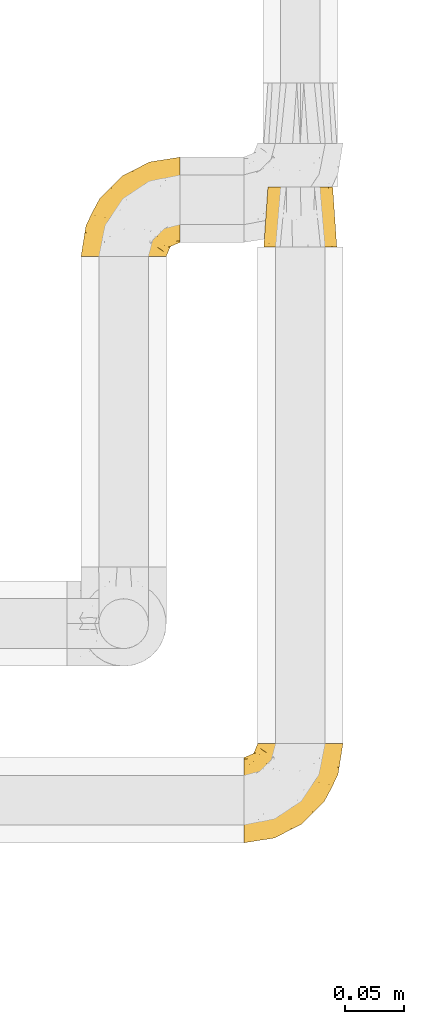
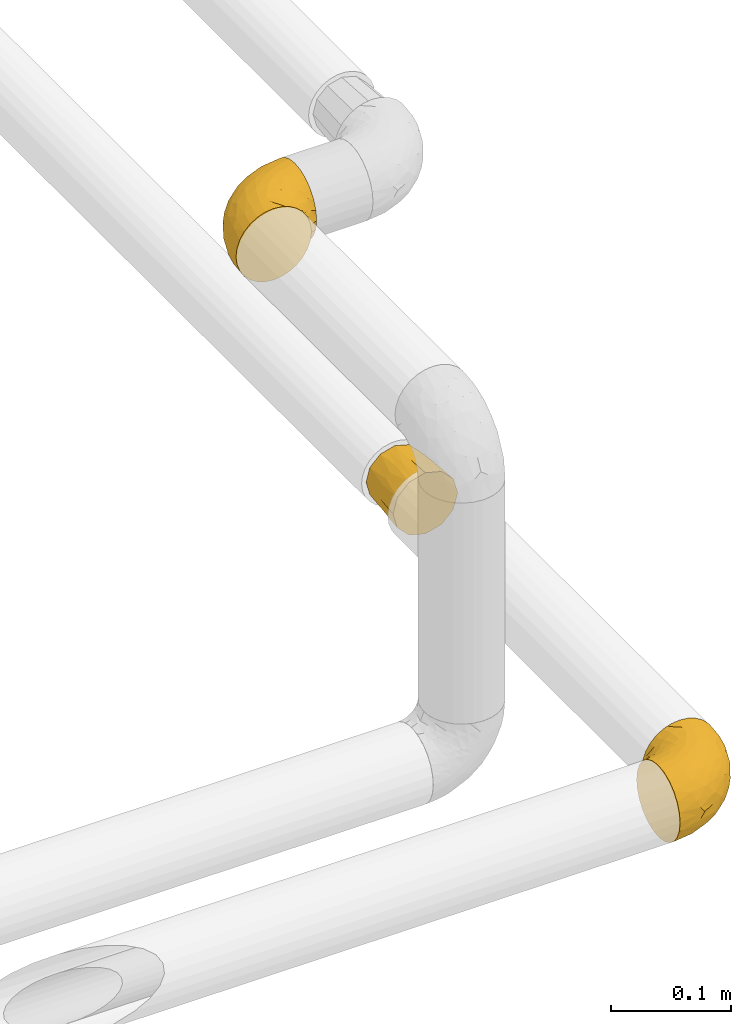
# One storey, part 24 of 39: 3 coverings.
"""IFC2X3 building model written with IfcOpenShell, lengths in millimetres."""

from ifc_helpers import new_model, entity, si_unit, converted_unit, derived_unit, direction, frame, origin, place, context, subcontext, project, spatial, faceted_brep, element, save


model = new_model("IFC2X3")

# Units and contexts
model_context = context("Model", 3, precision=0.01, world=origin(), true_north=direction((6.12303176911189e-17, 1.0)))
body_context = subcontext(model_context, "Body", "Model", "MODEL_VIEW")
ifc_project = project(units=[si_unit("LENGTHUNIT", "METRE", prefix="MILLI"), si_unit("AREAUNIT", "SQUARE_METRE"), si_unit("VOLUMEUNIT", "CUBIC_METRE"), converted_unit("PLANEANGLEUNIT", "DEGREE", entity("IfcRatioMeasure", 0.0174532925199433), si_unit("PLANEANGLEUNIT", "RADIAN"), dimensions=[0, 0, 0, 0, 0, 0, 0]), si_unit("MASSUNIT", "GRAM", prefix="KILO"), derived_unit("MASSDENSITYUNIT", [(si_unit("MASSUNIT", "GRAM", prefix="KILO"), 1), (si_unit("LENGTHUNIT", "METRE"), -3)]), derived_unit("MOMENTOFINERTIAUNIT", [(si_unit("LENGTHUNIT", "METRE"), 4)]), si_unit("TIMEUNIT", "SECOND"), si_unit("FREQUENCYUNIT", "HERTZ"), si_unit("THERMODYNAMICTEMPERATUREUNIT", "DEGREE_CELSIUS"), derived_unit("THERMALTRANSMITTANCEUNIT", [(si_unit("MASSUNIT", "GRAM", prefix="KILO"), 1), (si_unit("THERMODYNAMICTEMPERATUREUNIT", "KELVIN"), -1), (si_unit("TIMEUNIT", "SECOND"), -3)]), derived_unit("VOLUMETRICFLOWRATEUNIT", [(si_unit("LENGTHUNIT", "METRE"), 3), (si_unit("TIMEUNIT", "SECOND"), -1)]), derived_unit("MASSFLOWRATEUNIT", [(si_unit("MASSUNIT", "GRAM", prefix="KILO"), 1), (si_unit("TIMEUNIT", "SECOND"), -1)]), derived_unit("ROTATIONALFREQUENCYUNIT", [(si_unit("TIMEUNIT", "SECOND"), -1)]), si_unit("ELECTRICCURRENTUNIT", "AMPERE"), si_unit("ELECTRICVOLTAGEUNIT", "VOLT"), si_unit("POWERUNIT", "WATT"), si_unit("FORCEUNIT", "NEWTON", prefix="KILO"), si_unit("ILLUMINANCEUNIT", "LUX"), si_unit("LUMINOUSFLUXUNIT", "LUMEN"), si_unit("LUMINOUSINTENSITYUNIT", "CANDELA"), derived_unit("USERDEFINED", [(si_unit("MASSUNIT", "GRAM", prefix="KILO"), -1), (si_unit("LENGTHUNIT", "METRE"), -2), (si_unit("TIMEUNIT", "SECOND"), 3), (si_unit("LUMINOUSFLUXUNIT", "LUMEN"), 1)]), derived_unit("LINEARVELOCITYUNIT", [(si_unit("LENGTHUNIT", "METRE"), 1), (si_unit("TIMEUNIT", "SECOND"), -1)]), si_unit("PRESSUREUNIT", "PASCAL"), derived_unit("USERDEFINED", [(si_unit("LENGTHUNIT", "METRE"), -2), (si_unit("MASSUNIT", "GRAM", prefix="KILO"), 1), (si_unit("TIMEUNIT", "SECOND"), -2)]), derived_unit("LINEARFORCEUNIT", [(si_unit("MASSUNIT", "GRAM", prefix="KILO"), 1), (si_unit("LENGTHUNIT", "METRE"), 1), (si_unit("TIMEUNIT", "SECOND"), -2), (si_unit("LENGTHUNIT", "METRE"), -1)]), derived_unit("PLANARFORCEUNIT", [(si_unit("MASSUNIT", "GRAM", prefix="KILO"), 1), (si_unit("LENGTHUNIT", "METRE"), 1), (si_unit("TIMEUNIT", "SECOND"), -2), (si_unit("LENGTHUNIT", "METRE"), -2)])], contexts=[model_context])

# Site, building, storey
site_placement = place(None, origin())
site = spatial("IfcSite", under=ifc_project, at=site_placement, CompositionType="ELEMENT")
building_placement = place(site_placement, origin())
building = spatial("IfcBuilding", under=site, at=building_placement, CompositionType="ELEMENT")
storey_placement = place(building_placement, frame((0.0, 0.0, 24000.0)))
storey = spatial("IfcBuildingStorey", under=building, at=storey_placement, Name="07", CompositionType="ELEMENT", Elevation=24000.0)

# Coverings
covering_1_placement = place(storey_placement, frame((71732.42, 3195.35, 3047.4)))
element("IfcCovering", 1, at=covering_1_placement, inside=storey, Name=":ADSK_", ObjectType=":ADSK_", PredefinedType="INSULATION", context=body_context, shape_type="Brep", body=[
    faceted_brep([(59.44, 0.0, 17.1), (61.52, 0.0, 24.85), (63.6, 0.0, 32.6), (62.14, 0.0, 38.04), (60.68, 0.0, 43.48), (59.44, 0.0, 48.1), (53.77, 0.0, 53.77), (48.1, 0.0, 59.44), (40.35, 0.0, 61.52), (32.6, 0.0, 63.6), (27.15, 0.0, 62.14), (21.71, 0.0, 60.68), (17.1, 0.0, 59.44), (11.42, 0.0, 53.77), (5.75, 0.0, 48.1), (3.67, 0.0, 40.35), (1.6, 0.0, 32.6), (3.05, 0.0, 27.15), (4.51, 0.0, 21.71), (5.75, 0.0, 17.1), (11.42, 0.0, 11.42), (17.1, 0.0, 5.75), (24.85, 0.0, 3.67), (32.6, 0.0, 1.6), (38.04, 0.0, 3.05), (43.48, 0.0, 4.51), (48.1, 0.0, 5.75), (53.77, 0.0, 11.42), (46.35, 51.0, 56.41), (51.38, 51.0, 51.38), (56.41, 51.0, 46.35), (58.25, 51.0, 39.47), (60.1, 51.0, 32.6), (58.25, 51.0, 25.72), (56.41, 51.0, 18.85), (51.38, 51.0, 13.81), (46.35, 51.0, 8.78), (39.47, 51.0, 6.94), (32.6, 51.0, 5.1), (25.72, 51.0, 6.94), (18.85, 51.0, 8.78), (13.81, 51.0, 13.81), (8.78, 51.0, 18.85), (6.94, 51.0, 25.72), (5.1, 51.0, 32.6), (6.94, 51.0, 39.47), (8.78, 51.0, 46.35), (13.81, 51.0, 51.38), (18.85, 51.0, 56.41), (25.72, 51.0, 58.25), (32.6, 51.0, 60.1), (39.47, 51.0, 58.25), (6.2, 25.5, 19.99), (4.19, 24.88, 25.45), (10.36, 25.5, 13.59), (3.25, 24.18, 32.6), (19.99, 25.5, 6.2), (14.79, 25.5, 9.39), (32.6, 24.18, 3.25), (25.33, 25.5, 4.26), (45.2, 25.5, 6.2), (39.74, 24.88, 4.19), (51.6, 25.5, 10.36), (58.99, 25.5, 19.99), (55.8, 25.5, 14.79), (61.94, 24.18, 32.6), (60.93, 25.5, 25.33), (58.99, 25.5, 45.2), (61.0, 24.88, 39.74), (54.83, 25.5, 51.6), (45.2, 25.5, 58.99), (50.4, 25.5, 55.8), (32.6, 24.18, 61.94), (39.87, 25.5, 60.93), (19.99, 25.5, 58.99), (25.45, 24.88, 61.0), (13.59, 25.5, 54.83), (6.2, 25.5, 45.2), (9.39, 25.5, 50.4), (4.26, 25.5, 39.87)], [[[0, 1, 2, 3, 4, 5, 6, 7, 8, 9, 10, 11, 12, 13, 14, 15, 16, 17, 18, 19, 20, 21, 22, 23, 24, 25, 26, 27]], [[28, 29, 30, 31, 32, 33, 34, 35, 36, 37, 38, 39, 40, 41, 42, 43, 44, 45, 46, 47, 48, 49, 50, 51]], [[52, 43, 42]], [[52, 19, 18]], [[44, 43, 53]], [[17, 53, 18]], [[41, 54, 42]], [[17, 16, 55]], [[56, 21, 57]], [[41, 57, 54]], [[57, 41, 40]], [[58, 23, 59, 38]], [[57, 21, 20]], [[54, 19, 52]], [[53, 43, 52]], [[55, 44, 53]], [[57, 20, 54]], [[56, 57, 40]], [[19, 54, 20]], [[42, 54, 52]], [[18, 53, 52]], [[39, 59, 56]], [[56, 40, 39]], [[59, 22, 56]], [[22, 21, 56]], [[22, 59, 23]], [[55, 53, 17]], [[38, 59, 39]], [[60, 37, 36]], [[60, 26, 25]], [[38, 37, 61]], [[24, 61, 25]], [[35, 62, 36]], [[24, 23, 58]], [[63, 0, 64]], [[35, 64, 62]], [[64, 35, 34]], [[65, 2, 66, 32]], [[64, 0, 27]], [[62, 26, 60]], [[61, 37, 60]], [[58, 38, 61]], [[64, 27, 62]], [[63, 64, 34]], [[26, 62, 27]], [[36, 62, 60]], [[25, 61, 60]], [[33, 66, 63]], [[63, 34, 33]], [[66, 1, 63]], [[1, 0, 63]], [[1, 66, 2]], [[58, 61, 24]], [[32, 66, 33]], [[67, 31, 30]], [[67, 5, 4]], [[32, 31, 68]], [[3, 68, 4]], [[29, 69, 30]], [[3, 2, 65]], [[70, 7, 71]], [[29, 71, 69]], [[71, 29, 28]], [[72, 9, 73, 50]], [[71, 7, 6]], [[69, 5, 67]], [[68, 31, 67]], [[65, 32, 68]], [[71, 6, 69]], [[70, 71, 28]], [[5, 69, 6]], [[30, 69, 67]], [[4, 68, 67]], [[51, 73, 70]], [[70, 28, 51]], [[73, 8, 70]], [[8, 7, 70]], [[8, 73, 9]], [[65, 68, 3]], [[50, 73, 51]], [[74, 49, 48]], [[74, 12, 11]], [[50, 49, 75]], [[10, 75, 11]], [[47, 76, 48]], [[10, 9, 72]], [[77, 14, 78]], [[47, 78, 76]], [[78, 47, 46]], [[55, 16, 79, 44]], [[78, 14, 13]], [[76, 12, 74]], [[75, 49, 74]], [[72, 50, 75]], [[78, 13, 76]], [[77, 78, 46]], [[12, 76, 13]], [[48, 76, 74]], [[11, 75, 74]], [[45, 79, 77]], [[77, 46, 45]], [[79, 15, 77]], [[15, 14, 77]], [[15, 79, 16]], [[72, 75, 10]], [[44, 79, 45]]]),
])
covering_2_placement = place(storey_placement, frame((71715.42, 2687.56, 3042.2)))
element("IfcCovering", 2, at=covering_2_placement, inside=storey, Name=":ADSK_", ObjectType=":ADSK_", PredefinedType="INSULATION", context=body_context, shape_type="Brep", body=[
    faceted_brep([(57.65, 85.8, 73.09), (65.31, 85.8, 70.41), (72.17, 85.8, 66.09), (77.9, 85.8, 60.36), (82.21, 85.8, 53.5), (84.89, 85.8, 45.85), (85.8, 85.8, 37.8), (84.89, 85.8, 29.74), (82.21, 85.8, 22.08), (77.89, 85.8, 15.22), (72.16, 85.8, 9.49), (65.3, 85.8, 5.18), (57.65, 85.8, 2.5), (49.6, 85.8, 1.6), (44.33, 85.8, 2.19), (41.54, 85.8, 2.5), (37.71, 85.8, 3.84), (33.88, 85.8, 5.18), (27.02, 85.8, 9.5), (21.29, 85.8, 15.23), (16.98, 85.8, 22.09), (14.3, 85.8, 29.74), (13.4, 85.8, 37.8), (14.3, 85.8, 45.85), (16.98, 85.8, 53.51), (21.3, 85.8, 60.37), (27.03, 85.8, 66.1), (33.89, 85.8, 70.41), (37.72, 85.8, 71.75), (41.54, 85.8, 73.09), (44.33, 85.8, 73.4), (49.6, 85.8, 74.0), (1.6, 72.76, 28.43), (1.6, 69.15, 19.7), (1.6, 63.39, 12.2), (1.6, 59.64, 9.32), (1.6, 55.9, 6.45), (1.6, 51.53, 4.64), (1.6, 47.16, 2.83), (1.6, 43.08, 2.29), (1.6, 40.44, 1.94), (1.6, 37.8, 1.6), (1.6, 28.43, 2.83), (1.6, 19.7, 6.45), (1.6, 12.2, 12.2), (1.6, 6.45, 19.7), (1.6, 2.83, 28.43), (1.6, 1.6, 37.8), (1.6, 2.83, 47.16), (1.6, 6.45, 55.9), (1.6, 12.2, 63.39), (1.6, 19.7, 69.15), (1.6, 28.43, 72.76), (1.6, 37.8, 74.0), (1.6, 43.08, 73.3), (1.6, 47.16, 72.76), (1.6, 51.53, 70.95), (1.6, 55.9, 69.15), (1.6, 59.64, 66.27), (1.6, 63.39, 63.39), (1.6, 69.15, 55.9), (1.6, 72.76, 47.16), (1.6, 74.0, 37.8), (59.61, 27.78, 50.11), (60.4, 26.99, 37.8), (68.25, 36.07, 46.44), (27.62, 5.72, 37.8), (22.94, 4.9, 44.03), (19.4, 4.42, 37.8), (42.09, 13.52, 47.59), (33.53, 14.0, 57.17), (21.38, 6.28, 50.38), (16.47, 9.64, 58.65), (54.23, 70.93, 73.37), (38.23, 36.05, 71.27), (19.11, 24.02, 70.16), (36.76, 25.93, 66.97), (17.03, 32.56, 73.22), (19.96, 41.45, 74.0), (12.51, 39.97, 74.0), (9.78, 39.42, 74.0), (7.05, 38.88, 74.0), (21.71, 16.62, 64.86), (62.55, 71.64, 70.93), (75.89, 47.83, 45.2), (81.73, 65.91, 48.57), (74.04, 51.38, 54.32), (47.66, 52.81, 72.95), (45.94, 67.43, 74.0), (43.34, 63.53, 74.0), (40.74, 59.64, 74.0), (38.14, 55.75, 74.0), (35.54, 51.85, 74.0), (51.41, 41.26, 68.72), (30.21, 38.98, 73.34), (68.92, 70.65, 67.28), (74.03, 65.64, 61.7), (79.55, 71.08, 55.94), (82.98, 67.99, 37.8), (67.24, 38.62, 53.02), (55.48, 28.73, 57.31), (48.51, 80.34, 74.0), (47.42, 74.88, 74.0), (65.49, 52.52, 64.86), (64.99, 41.68, 59.15), (58.95, 56.44, 70.05), (45.7, 19.89, 55.98), (39.35, 11.7, 37.8), (53.72, 34.04, 63.54), (42.9, 22.66, 61.4), (81.67, 59.78, 37.8), (69.72, 36.3, 37.8), (75.69, 48.04, 37.8), (31.64, 49.25, 74.0), (27.75, 46.65, 74.0), (23.86, 44.05, 74.0), (51.09, 17.68, 37.8), (17.47, 56.47, 70.9), (18.36, 60.92, 69.2), (12.71, 63.29, 65.83), (7.84, 45.31, 73.31), (7.85, 59.83, 67.07), (6.14, 64.71, 62.53), (11.2, 74.49, 52.3), (14.99, 76.83, 54.94), (11.85, 78.01, 46.54), (23.69, 56.9, 72.08), (20.48, 50.18, 73.17), (14.49, 71.99, 59.32), (9.51, 70.83, 56.36), (6.6, 73.18, 48.99), (6.61, 68.29, 58.36), (26.46, 80.74, 66.05), (20.83, 78.17, 61.56), (28.69, 73.83, 68.98), (41.38, 76.97, 73.26), (7.16, 54.72, 70.05), (16.97, 47.37, 73.39), (12.64, 54.39, 70.87), (18.4, 74.3, 61.17), (35.97, 75.54, 71.9), (16.38, 66.46, 65.19), (11.31, 80.75, 37.8), (13.68, 81.71, 46.04), (15.78, 81.69, 52.15), (24.06, 72.63, 66.57), (9.94, 77.45, 37.8), (35.3, 62.19, 73.34), (36.41, 67.73, 72.91), (6.64, 76.08, 37.8), (10.52, 48.26, 72.75), (23.5, 62.83, 70.14), (29.62, 62.31, 72.14), (20.86, 68.86, 66.28), (29.66, 56.53, 73.22), (6.61, 68.29, 17.23), (6.59, 73.17, 26.6), (6.13, 64.71, 13.06), (48.51, 80.34, 1.6), (47.43, 74.88, 1.6), (13.67, 81.71, 29.56), (14.98, 76.83, 20.66), (15.78, 81.69, 23.45), (20.82, 78.17, 14.04), (4.33, 38.34, 1.6), (12.51, 39.97, 1.6), (7.05, 38.88, 1.6), (9.51, 70.83, 19.23), (11.19, 74.49, 23.3), (14.48, 72.0, 16.29), (10.19, 59.87, 8.09), (12.64, 54.39, 4.72), (7.16, 54.72, 5.54), (35.96, 75.53, 3.69), (10.52, 48.26, 2.84), (20.48, 50.18, 2.42), (17.47, 56.47, 4.69), (23.68, 56.9, 3.52), (16.97, 47.37, 2.21), (11.85, 78.01, 29.05), (7.85, 45.31, 2.29), (26.45, 80.74, 9.55), (18.4, 74.3, 14.43), (41.37, 76.96, 2.33), (20.85, 68.85, 9.32), (29.62, 62.32, 3.45), (23.5, 62.83, 5.45), (16.36, 66.46, 10.41), (35.87, 67.82, 2.81), (28.67, 73.83, 6.62), (45.94, 67.43, 1.6), (12.71, 63.29, 9.76), (24.04, 72.63, 9.03), (29.66, 56.54, 2.37), (30.95, 67.39, 4.15), (35.8, 62.12, 2.17), (43.34, 63.53, 1.6), (27.75, 46.65, 1.6), (31.64, 49.25, 1.6), (19.97, 41.45, 1.6), (23.86, 44.05, 1.6), (18.36, 60.93, 6.39), (40.74, 59.64, 1.6), (35.54, 51.85, 1.6), (38.14, 55.75, 1.6), (38.23, 36.06, 4.32), (17.03, 32.56, 2.37), (30.2, 38.98, 2.25), (64.98, 41.69, 16.43), (55.47, 28.72, 18.27), (53.71, 34.05, 12.04), (36.76, 25.93, 8.62), (51.4, 41.26, 6.87), (65.48, 52.53, 10.72), (47.66, 52.81, 2.65), (59.61, 27.78, 25.48), (45.7, 19.9, 19.59), (19.11, 24.02, 5.43), (22.94, 4.9, 31.57), (21.39, 6.28, 25.21), (58.94, 56.45, 5.53), (16.48, 9.64, 16.94), (21.71, 16.62, 10.73), (33.54, 14.0, 18.43), (74.04, 51.38, 21.26), (81.72, 65.91, 27.01), (75.89, 47.82, 30.39), (54.23, 70.94, 2.22), (74.02, 65.64, 13.88), (68.91, 70.65, 8.3), (42.09, 13.52, 28.0), (68.25, 36.08, 29.14), (67.24, 38.62, 22.56), (79.54, 71.07, 19.65), (42.91, 22.68, 14.18), (62.54, 71.64, 4.66)], [[[0, 1, 2, 3, 4, 5, 6, 7, 8, 9, 10, 11, 12, 13, 14, 15, 16, 17, 18, 19, 20, 21, 22, 23, 24, 25, 26, 27, 28, 29, 30, 31]], [[32, 33, 34, 35, 36, 37, 38, 39, 40, 41, 42, 43, 44, 45, 46, 47, 48, 49, 50, 51, 52, 53, 54, 55, 56, 57, 58, 59, 60, 61, 62]], [[63, 64, 65]], [[66, 67, 68]], [[69, 70, 71]], [[71, 70, 72]], [[73, 0, 31]], [[74, 75, 76]], [[49, 48, 71]], [[77, 78, 79, 80, 81, 53]], [[50, 82, 51]], [[72, 50, 49]], [[1, 0, 83]], [[84, 85, 86]], [[87, 88, 89, 90, 91, 92]], [[53, 52, 77]], [[93, 74, 76]], [[4, 85, 5]], [[94, 78, 77]], [[95, 2, 1]], [[95, 96, 2]], [[75, 51, 82]], [[85, 4, 97]], [[50, 72, 82]], [[97, 4, 3]], [[85, 98, 5]], [[94, 87, 92]], [[74, 77, 75]], [[99, 100, 63]], [[96, 3, 2]], [[73, 31, 101, 102, 88]], [[96, 103, 104]], [[48, 68, 67]], [[84, 99, 65]], [[105, 83, 73]], [[105, 95, 83]], [[100, 106, 63]], [[86, 96, 104]], [[97, 86, 85]], [[67, 107, 69]], [[100, 108, 109]], [[84, 110, 85]], [[93, 87, 74]], [[96, 95, 103]], [[69, 71, 67]], [[70, 69, 106]], [[3, 96, 97]], [[86, 97, 96]], [[83, 95, 1]], [[103, 95, 105]], [[93, 103, 105]], [[103, 108, 104]], [[75, 77, 52]], [[94, 77, 74]], [[51, 75, 52]], [[75, 82, 76]], [[109, 82, 70]], [[93, 76, 108]], [[88, 87, 73]], [[105, 73, 87]], [[84, 86, 99]], [[84, 111, 112, 110]], [[98, 85, 110]], [[98, 6, 5]], [[73, 83, 0]], [[71, 72, 49]], [[82, 72, 70]], [[87, 94, 74]], [[94, 92, 113, 114, 115, 78]], [[48, 47, 68]], [[48, 67, 71]], [[100, 104, 108]], [[99, 86, 104]], [[109, 108, 76]], [[100, 109, 106]], [[82, 109, 76]], [[106, 109, 70]], [[100, 99, 104]], [[99, 63, 65]], [[69, 116, 63]], [[111, 84, 65]], [[64, 63, 116]], [[64, 111, 65]], [[63, 106, 69]], [[103, 93, 108]], [[87, 93, 105]], [[107, 67, 66]], [[107, 116, 69]], [[117, 118, 119]], [[80, 120, 55]], [[121, 119, 122]], [[120, 56, 55]], [[123, 124, 125]], [[114, 126, 127]], [[101, 31, 30, 29, 102]], [[123, 128, 124]], [[129, 123, 130]], [[60, 122, 131]], [[132, 133, 134]], [[28, 27, 135]], [[131, 61, 60]], [[122, 60, 59]], [[136, 137, 138]], [[124, 128, 139]], [[132, 26, 25]], [[131, 130, 61]], [[140, 135, 27]], [[102, 28, 135]], [[119, 118, 141]], [[58, 136, 121]], [[140, 27, 26]], [[54, 53, 81, 80, 55]], [[22, 142, 143]], [[23, 144, 24]], [[24, 144, 133]], [[25, 24, 133]], [[134, 133, 145]], [[125, 142, 146]], [[124, 143, 125]], [[147, 90, 148]], [[124, 144, 143]], [[149, 125, 146]], [[150, 57, 56]], [[137, 78, 115]], [[130, 62, 61]], [[132, 140, 26]], [[151, 152, 153]], [[140, 134, 148]], [[148, 89, 140]], [[120, 78, 150]], [[115, 127, 137]], [[137, 136, 150]], [[78, 120, 80, 79]], [[150, 56, 120]], [[152, 151, 154]], [[127, 117, 138]], [[144, 23, 143]], [[133, 144, 124]], [[152, 91, 147]], [[145, 152, 134]], [[22, 143, 23]], [[142, 125, 143]], [[130, 125, 149]], [[128, 123, 129]], [[141, 129, 119]], [[124, 139, 133]], [[125, 130, 123]], [[62, 130, 149]], [[128, 153, 139]], [[145, 139, 153]], [[92, 154, 113]], [[127, 115, 114]], [[117, 127, 126]], [[118, 117, 126]], [[121, 117, 119]], [[138, 137, 127]], [[78, 137, 150]], [[151, 118, 126]], [[118, 151, 141]], [[153, 128, 141]], [[129, 141, 128]], [[102, 29, 28]], [[140, 88, 135]], [[88, 102, 135]], [[133, 132, 25]], [[140, 132, 134]], [[121, 122, 59]], [[131, 119, 129]], [[121, 59, 58]], [[121, 138, 117]], [[136, 58, 57]], [[150, 136, 57]], [[121, 136, 138]], [[119, 131, 122]], [[131, 129, 130]], [[139, 145, 133]], [[152, 145, 153]], [[89, 148, 90]], [[89, 88, 140]], [[147, 134, 152]], [[134, 147, 148]], [[126, 114, 113]], [[152, 154, 91]], [[91, 90, 147]], [[151, 153, 141]], [[154, 151, 126]], [[113, 154, 126]], [[91, 154, 92]], [[155, 32, 156]], [[33, 157, 34]], [[62, 149, 156]], [[14, 13, 158, 159, 15]], [[160, 22, 21]], [[161, 162, 163]], [[164, 41, 40, 39, 38, 165, 166]], [[167, 168, 169]], [[157, 170, 34]], [[171, 172, 170]], [[17, 173, 18]], [[174, 37, 36]], [[175, 176, 177]], [[178, 171, 175]], [[146, 179, 149]], [[168, 179, 161]], [[161, 160, 162]], [[162, 160, 21]], [[38, 37, 180]], [[19, 18, 181]], [[20, 19, 163]], [[161, 182, 169]], [[17, 183, 173]], [[184, 185, 186]], [[169, 187, 167]], [[188, 189, 173]], [[159, 190, 183]], [[16, 159, 183]], [[156, 179, 168]], [[191, 157, 155]], [[192, 163, 189]], [[20, 162, 21]], [[146, 142, 179]], [[181, 163, 19]], [[177, 186, 193]], [[178, 172, 171]], [[167, 156, 168]], [[185, 194, 195]], [[181, 173, 189]], [[173, 196, 188]], [[197, 177, 198]], [[199, 165, 180]], [[180, 165, 38]], [[200, 178, 175]], [[37, 174, 180]], [[199, 180, 174]], [[175, 197, 200]], [[177, 176, 201]], [[163, 162, 20]], [[160, 161, 179]], [[192, 185, 184]], [[194, 189, 188]], [[179, 142, 160]], [[22, 160, 142]], [[169, 168, 161]], [[155, 156, 167]], [[182, 161, 163]], [[184, 186, 187]], [[62, 156, 32]], [[179, 156, 149]], [[192, 182, 163]], [[184, 169, 182]], [[176, 175, 171]], [[174, 178, 199]], [[197, 175, 177]], [[170, 176, 171]], [[201, 176, 191]], [[199, 178, 200]], [[178, 174, 172]], [[187, 201, 191]], [[201, 187, 186]], [[167, 187, 191]], [[169, 184, 187]], [[173, 183, 190]], [[16, 15, 159]], [[173, 181, 18]], [[163, 181, 189]], [[155, 157, 33]], [[170, 157, 191]], [[176, 170, 191]], [[35, 170, 172]], [[35, 172, 36]], [[34, 170, 35]], [[174, 36, 172]], [[32, 155, 33]], [[191, 155, 167]], [[192, 189, 194]], [[182, 192, 184]], [[193, 198, 177]], [[183, 17, 16]], [[196, 173, 190]], [[196, 202, 188]], [[193, 186, 185]], [[201, 186, 177]], [[188, 195, 194]], [[203, 193, 204]], [[188, 202, 195]], [[192, 194, 185]], [[202, 204, 195]], [[185, 195, 204]], [[204, 193, 185]], [[198, 193, 203]], [[205, 206, 207]], [[208, 209, 210]], [[210, 211, 212]], [[210, 213, 208]], [[214, 203, 204, 202, 196, 190]], [[206, 41, 164, 166, 165, 199]], [[215, 216, 209]], [[206, 217, 42]], [[218, 46, 219]], [[207, 214, 205]], [[212, 214, 220]], [[221, 219, 45]], [[45, 219, 46]], [[221, 222, 223]], [[224, 225, 226]], [[222, 44, 43]], [[222, 217, 211]], [[220, 214, 227]], [[227, 190, 159, 158, 13]], [[217, 43, 42]], [[13, 12, 227]], [[225, 8, 7]], [[9, 228, 10]], [[10, 229, 11]], [[208, 213, 228]], [[228, 229, 10]], [[230, 219, 223]], [[231, 232, 226]], [[231, 64, 215]], [[225, 233, 8]], [[229, 213, 220]], [[233, 9, 8]], [[110, 225, 98]], [[41, 206, 42]], [[222, 211, 234]], [[224, 228, 233]], [[225, 7, 98]], [[221, 45, 44]], [[226, 110, 112, 111]], [[11, 229, 235]], [[46, 218, 68]], [[230, 107, 218]], [[223, 234, 216]], [[107, 66, 218]], [[224, 233, 225]], [[228, 9, 233]], [[213, 229, 228]], [[235, 229, 220]], [[208, 228, 224]], [[212, 213, 210]], [[207, 206, 199]], [[205, 211, 217]], [[205, 217, 206]], [[43, 217, 222]], [[212, 211, 205]], [[210, 209, 234]], [[227, 12, 235]], [[214, 190, 227]], [[110, 226, 225]], [[232, 231, 215]], [[7, 6, 98]], [[227, 235, 220]], [[12, 11, 235]], [[222, 221, 44]], [[219, 221, 223]], [[207, 199, 200, 197, 198, 203]], [[214, 207, 203]], [[68, 218, 66]], [[68, 47, 46]], [[230, 218, 219]], [[224, 232, 208]], [[208, 232, 209]], [[216, 215, 230]], [[210, 234, 211]], [[216, 234, 209]], [[222, 234, 223]], [[226, 232, 224]], [[209, 232, 215]], [[226, 111, 231]], [[64, 116, 215]], [[231, 111, 64]], [[116, 230, 215]], [[230, 223, 216]], [[214, 212, 205]], [[213, 212, 220]], [[230, 116, 107]]]),
])
covering_3_placement = place(storey_placement, frame((71577.22, 3185.76, 3362.2)))
element("IfcCovering", 3, at=covering_3_placement, inside=storey, Name=":ADSK_", ObjectType=":ADSK_", PredefinedType="INSULATION", context=body_context, shape_type="Brep", body=[
    faceted_brep([(37.8, 1.6, 74.0), (29.74, 1.6, 73.09), (22.08, 1.6, 70.41), (15.22, 1.6, 66.09), (9.49, 1.6, 60.36), (5.18, 1.6, 53.5), (2.5, 1.6, 45.85), (1.6, 1.6, 37.8), (2.5, 1.6, 29.74), (5.18, 1.6, 22.08), (9.5, 1.6, 15.22), (15.23, 1.6, 9.49), (22.09, 1.6, 5.18), (29.74, 1.6, 2.5), (37.8, 1.6, 1.6), (43.06, 1.6, 2.19), (45.85, 1.6, 2.5), (49.68, 1.6, 3.84), (53.51, 1.6, 5.18), (60.37, 1.6, 9.5), (66.1, 1.6, 15.23), (70.41, 1.6, 22.09), (73.09, 1.6, 29.74), (74.0, 1.6, 37.8), (73.09, 1.6, 45.85), (70.41, 1.6, 53.51), (66.09, 1.6, 60.37), (60.36, 1.6, 66.1), (53.5, 1.6, 70.41), (49.67, 1.6, 71.75), (45.85, 1.6, 73.09), (43.06, 1.6, 73.4), (85.8, 14.63, 28.43), (85.8, 18.25, 19.7), (85.8, 24.0, 12.2), (85.8, 27.75, 9.32), (85.8, 31.5, 6.45), (85.8, 35.86, 4.64), (85.8, 40.23, 2.83), (85.8, 44.31, 2.29), (85.8, 46.95, 1.94), (85.8, 49.6, 1.6), (85.8, 58.96, 2.83), (85.8, 67.7, 6.45), (85.8, 75.19, 12.2), (85.8, 80.95, 19.7), (85.8, 84.56, 28.43), (85.8, 85.8, 37.8), (85.8, 84.56, 47.16), (85.8, 80.95, 55.9), (85.8, 75.19, 63.39), (85.8, 67.7, 69.15), (85.8, 58.96, 72.76), (85.8, 49.6, 74.0), (85.8, 44.31, 73.3), (85.8, 40.23, 72.76), (85.8, 35.86, 70.95), (85.8, 31.5, 69.15), (85.8, 27.75, 66.27), (85.8, 24.0, 63.39), (85.8, 18.25, 55.9), (85.8, 14.63, 47.16), (85.8, 13.4, 37.8), (27.78, 59.61, 50.11), (26.99, 60.4, 37.8), (19.15, 51.32, 46.44), (59.78, 81.67, 37.8), (64.45, 82.49, 44.03), (67.99, 82.98, 37.8), (45.3, 73.87, 47.59), (53.86, 73.39, 57.17), (66.01, 81.11, 50.38), (70.92, 77.75, 58.65), (33.16, 16.46, 73.37), (49.16, 51.34, 71.27), (68.28, 63.37, 70.16), (50.64, 61.46, 66.97), (70.36, 54.83, 73.22), (67.43, 45.94, 74.0), (74.88, 47.42, 74.0), (77.61, 47.97, 74.0), (80.34, 48.51, 74.0), (65.68, 70.77, 64.86), (24.84, 15.75, 70.93), (11.5, 39.56, 45.19), (5.67, 21.48, 48.57), (13.35, 36.01, 54.32), (39.73, 34.58, 72.94), (41.45, 19.96, 74.0), (44.05, 23.86, 74.0), (46.65, 27.75, 74.0), (49.25, 31.64, 74.0), (51.85, 35.54, 74.0), (35.98, 46.13, 68.72), (57.18, 48.41, 73.34), (18.48, 16.74, 67.28), (13.36, 21.75, 61.7), (7.85, 16.31, 55.94), (4.42, 19.4, 37.8), (20.15, 48.77, 53.02), (31.91, 58.66, 57.31), (38.88, 7.05, 74.0), (39.97, 12.51, 74.0), (21.9, 34.87, 64.86), (22.4, 45.71, 59.15), (28.44, 30.95, 70.05), (41.69, 67.5, 55.98), (48.04, 75.69, 37.8), (33.67, 53.35, 63.54), (44.49, 64.73, 61.4), (5.72, 27.61, 37.8), (17.68, 51.09, 37.8), (11.7, 39.35, 37.8), (55.75, 38.14, 74.0), (59.64, 40.74, 74.0), (63.53, 43.34, 74.0), (36.3, 69.71, 37.8), (69.92, 30.92, 70.9), (69.03, 26.47, 69.2), (74.68, 24.1, 65.83), (79.55, 42.08, 73.31), (79.54, 27.56, 67.07), (81.25, 22.68, 62.53), (76.19, 12.9, 52.3), (72.4, 10.56, 54.94), (75.54, 9.38, 46.54), (63.7, 30.49, 72.08), (66.91, 37.21, 73.17), (72.9, 15.4, 59.32), (77.88, 16.56, 56.36), (80.8, 14.21, 48.99), (80.78, 19.1, 58.36), (60.93, 6.65, 66.05), (66.56, 9.22, 61.56), (58.7, 13.56, 68.98), (46.01, 10.43, 73.26), (80.23, 32.68, 70.05), (70.42, 40.02, 73.39), (74.75, 33.01, 70.87), (68.99, 13.09, 61.17), (51.42, 11.85, 71.9), (71.01, 20.93, 65.19), (76.08, 6.64, 37.8), (73.72, 5.68, 46.04), (71.61, 5.7, 52.15), (63.33, 14.76, 66.57), (77.45, 9.94, 37.8), (52.1, 25.2, 73.34), (50.98, 19.66, 72.91), (80.75, 11.31, 37.8), (76.87, 39.13, 72.75), (63.89, 24.56, 70.14), (57.77, 25.09, 72.14), (66.53, 18.54, 66.28), (57.73, 30.86, 73.22), (80.78, 19.1, 17.23), (80.8, 14.22, 26.6), (81.26, 22.68, 13.06), (38.88, 7.05, 1.6), (39.97, 12.51, 1.6), (73.72, 5.68, 29.56), (72.41, 10.57, 20.66), (71.61, 5.7, 23.45), (66.57, 9.22, 14.04), (74.88, 47.42, 1.6), (80.34, 48.51, 1.6), (83.07, 49.05, 1.6), (77.88, 16.56, 19.23), (76.2, 12.9, 23.3), (72.91, 15.39, 16.29), (77.2, 27.52, 8.09), (74.75, 33.0, 4.72), (80.23, 32.67, 5.54), (51.43, 11.86, 3.69), (76.87, 39.13, 2.84), (66.92, 37.21, 2.42), (69.93, 30.92, 4.69), (63.71, 30.49, 3.51), (70.42, 40.02, 2.2), (75.54, 9.38, 29.05), (79.55, 42.08, 2.29), (60.94, 6.65, 9.55), (69.0, 13.09, 14.43), (46.02, 10.43, 2.33), (57.77, 25.08, 3.45), (57.73, 30.85, 2.37), (63.89, 24.56, 5.45), (71.03, 20.93, 10.41), (51.53, 19.57, 2.81), (58.72, 13.56, 6.62), (41.45, 19.96, 1.6), (74.69, 24.1, 9.76), (63.35, 14.76, 9.03), (49.25, 31.64, 1.6), (56.44, 20.0, 4.15), (51.59, 25.27, 2.17), (44.05, 23.86, 1.6), (59.64, 40.74, 1.6), (55.75, 38.14, 1.6), (67.43, 45.94, 1.6), (63.53, 43.34, 1.6), (69.03, 26.46, 6.39), (66.54, 18.54, 9.32), (46.65, 27.75, 1.6), (51.85, 35.54, 1.6), (49.16, 51.33, 4.32), (70.36, 54.83, 2.37), (57.19, 48.41, 2.25), (22.41, 45.7, 16.43), (31.92, 58.67, 18.27), (33.68, 53.34, 12.04), (50.63, 61.46, 8.62), (35.99, 46.13, 6.87), (21.91, 34.86, 10.72), (39.73, 34.58, 2.64), (27.78, 59.61, 25.48), (41.7, 67.49, 19.59), (68.28, 63.37, 5.43), (64.45, 82.49, 31.57), (66.0, 81.11, 25.21), (28.45, 30.94, 5.53), (70.92, 77.75, 16.94), (65.68, 70.77, 10.73), (53.85, 73.39, 18.42), (13.35, 36.01, 21.26), (5.67, 21.48, 27.01), (11.5, 39.57, 30.39), (33.16, 16.45, 2.22), (13.37, 21.75, 13.88), (18.49, 16.74, 8.3), (45.3, 73.87, 28.0), (19.14, 51.31, 29.14), (20.15, 48.77, 22.56), (7.85, 16.32, 19.64), (44.48, 64.71, 14.18), (24.85, 15.75, 4.66)], [[[0, 1, 2, 3, 4, 5, 6, 7, 8, 9, 10, 11, 12, 13, 14, 15, 16, 17, 18, 19, 20, 21, 22, 23, 24, 25, 26, 27, 28, 29, 30, 31]], [[32, 33, 34, 35, 36, 37, 38, 39, 40, 41, 42, 43, 44, 45, 46, 47, 48, 49, 50, 51, 52, 53, 54, 55, 56, 57, 58, 59, 60, 61, 62]], [[63, 64, 65]], [[66, 67, 68]], [[69, 70, 71]], [[71, 70, 72]], [[73, 1, 0]], [[74, 75, 76]], [[49, 48, 71]], [[77, 78, 79, 80, 81, 53]], [[50, 82, 51]], [[72, 50, 49]], [[2, 1, 83]], [[84, 85, 86]], [[87, 88, 89, 90, 91, 92]], [[53, 52, 77]], [[93, 74, 76]], [[5, 85, 6]], [[94, 78, 77]], [[95, 3, 2]], [[95, 96, 3]], [[75, 51, 82]], [[85, 5, 97]], [[50, 72, 82]], [[97, 5, 4]], [[85, 98, 6]], [[94, 87, 92]], [[74, 77, 75]], [[99, 100, 63]], [[96, 4, 3]], [[73, 0, 101, 102, 88]], [[96, 103, 104]], [[48, 68, 67]], [[84, 99, 65]], [[105, 83, 73]], [[105, 95, 83]], [[100, 106, 63]], [[86, 96, 104]], [[97, 86, 85]], [[67, 107, 69]], [[100, 108, 109]], [[84, 110, 85]], [[93, 87, 74]], [[96, 95, 103]], [[69, 71, 67]], [[70, 69, 106]], [[4, 96, 97]], [[86, 97, 96]], [[83, 95, 2]], [[103, 95, 105]], [[93, 103, 105]], [[103, 108, 104]], [[75, 77, 52]], [[94, 77, 74]], [[51, 75, 52]], [[75, 82, 76]], [[109, 82, 70]], [[93, 76, 108]], [[88, 87, 73]], [[105, 73, 87]], [[84, 86, 99]], [[84, 111, 112, 110]], [[98, 85, 110]], [[98, 7, 6]], [[73, 83, 1]], [[71, 72, 49]], [[82, 72, 70]], [[87, 94, 74]], [[94, 92, 113, 114, 115, 78]], [[48, 47, 68]], [[48, 67, 71]], [[100, 104, 108]], [[99, 86, 104]], [[109, 108, 76]], [[100, 109, 106]], [[82, 109, 76]], [[106, 109, 70]], [[100, 99, 104]], [[99, 63, 65]], [[69, 116, 63]], [[111, 84, 65]], [[64, 63, 116]], [[64, 111, 65]], [[63, 106, 69]], [[103, 93, 108]], [[87, 93, 105]], [[107, 67, 66]], [[107, 116, 69]], [[117, 118, 119]], [[80, 120, 55]], [[121, 119, 122]], [[120, 56, 55]], [[123, 124, 125]], [[114, 126, 127]], [[101, 0, 31, 30, 102]], [[123, 128, 124]], [[129, 123, 130]], [[60, 122, 131]], [[132, 133, 134]], [[29, 28, 135]], [[131, 61, 60]], [[122, 60, 59]], [[136, 137, 138]], [[124, 128, 139]], [[132, 27, 26]], [[131, 130, 61]], [[140, 135, 28]], [[102, 29, 135]], [[119, 118, 141]], [[58, 136, 121]], [[140, 28, 27]], [[54, 53, 81, 80, 55]], [[23, 142, 143]], [[24, 144, 25]], [[25, 144, 133]], [[26, 25, 133]], [[134, 133, 145]], [[125, 142, 146]], [[124, 143, 125]], [[147, 90, 148]], [[124, 144, 143]], [[149, 125, 146]], [[150, 57, 56]], [[137, 78, 115]], [[130, 62, 61]], [[132, 140, 27]], [[151, 152, 153]], [[140, 134, 148]], [[148, 89, 140]], [[120, 78, 150]], [[115, 127, 137]], [[137, 136, 150]], [[78, 120, 80, 79]], [[150, 56, 120]], [[91, 154, 92]], [[127, 117, 138]], [[144, 24, 143]], [[133, 144, 124]], [[152, 91, 147]], [[145, 152, 134]], [[23, 143, 24]], [[142, 125, 143]], [[130, 125, 149]], [[128, 123, 129]], [[141, 129, 119]], [[124, 139, 133]], [[125, 130, 123]], [[62, 130, 149]], [[128, 153, 139]], [[145, 139, 153]], [[92, 154, 113]], [[127, 115, 114]], [[117, 127, 126]], [[118, 117, 126]], [[121, 117, 119]], [[138, 137, 127]], [[78, 137, 150]], [[151, 118, 126]], [[118, 151, 141]], [[153, 128, 141]], [[129, 141, 128]], [[102, 30, 29]], [[140, 88, 135]], [[88, 102, 135]], [[133, 132, 26]], [[140, 132, 134]], [[121, 122, 59]], [[131, 119, 129]], [[121, 59, 58]], [[121, 138, 117]], [[136, 58, 57]], [[150, 136, 57]], [[121, 136, 138]], [[119, 131, 122]], [[131, 129, 130]], [[139, 145, 133]], [[152, 145, 153]], [[89, 148, 90]], [[89, 88, 140]], [[147, 134, 152]], [[134, 147, 148]], [[126, 114, 113]], [[152, 154, 91]], [[91, 90, 147]], [[151, 153, 141]], [[154, 151, 126]], [[151, 154, 152]], [[113, 154, 126]], [[155, 32, 156]], [[33, 157, 34]], [[62, 149, 156]], [[15, 14, 158, 159, 16]], [[160, 23, 22]], [[161, 162, 163]], [[40, 39, 38, 164, 165, 166, 41]], [[167, 168, 169]], [[157, 170, 34]], [[171, 172, 170]], [[18, 173, 19]], [[174, 37, 36]], [[175, 176, 177]], [[178, 171, 175]], [[146, 179, 149]], [[168, 179, 161]], [[161, 160, 162]], [[162, 160, 22]], [[38, 37, 180]], [[20, 19, 181]], [[21, 20, 163]], [[161, 182, 169]], [[18, 183, 173]], [[184, 185, 186]], [[169, 187, 167]], [[188, 189, 173]], [[159, 190, 183]], [[17, 159, 183]], [[156, 179, 168]], [[191, 157, 155]], [[192, 163, 189]], [[21, 162, 22]], [[146, 142, 179]], [[181, 163, 20]], [[185, 184, 193]], [[178, 172, 171]], [[167, 156, 168]], [[184, 194, 195]], [[181, 173, 189]], [[173, 196, 188]], [[197, 177, 198]], [[199, 164, 180]], [[180, 164, 38]], [[200, 178, 175]], [[37, 174, 180]], [[199, 180, 174]], [[175, 197, 200]], [[177, 176, 201]], [[163, 162, 21]], [[160, 161, 179]], [[192, 184, 202]], [[194, 189, 188]], [[179, 142, 160]], [[23, 160, 142]], [[169, 168, 161]], [[155, 156, 167]], [[182, 161, 163]], [[202, 186, 187]], [[62, 156, 32]], [[179, 156, 149]], [[192, 182, 163]], [[202, 169, 182]], [[176, 175, 171]], [[174, 178, 199]], [[197, 175, 177]], [[170, 176, 171]], [[201, 176, 191]], [[199, 178, 200]], [[178, 174, 172]], [[187, 201, 191]], [[201, 187, 186]], [[167, 187, 191]], [[169, 202, 187]], [[173, 183, 190]], [[17, 16, 159]], [[173, 181, 19]], [[163, 181, 189]], [[155, 157, 33]], [[170, 157, 191]], [[176, 170, 191]], [[35, 170, 172]], [[35, 172, 36]], [[34, 170, 35]], [[174, 36, 172]], [[32, 155, 33]], [[191, 155, 167]], [[192, 189, 194]], [[182, 192, 202]], [[185, 198, 177]], [[183, 18, 17]], [[196, 173, 190]], [[196, 203, 188]], [[201, 186, 177]], [[202, 184, 186]], [[188, 195, 194]], [[204, 185, 193]], [[188, 203, 195]], [[192, 194, 184]], [[203, 193, 195]], [[184, 195, 193]], [[198, 185, 204]], [[186, 185, 177]], [[205, 206, 207]], [[208, 209, 210]], [[210, 211, 212]], [[210, 213, 208]], [[214, 204, 193, 203, 196, 190]], [[206, 41, 166, 165, 164, 199]], [[215, 216, 209]], [[206, 217, 42]], [[218, 46, 219]], [[207, 214, 205]], [[212, 214, 220]], [[221, 219, 45]], [[45, 219, 46]], [[221, 222, 223]], [[224, 225, 226]], [[222, 44, 43]], [[222, 217, 211]], [[220, 214, 227]], [[227, 190, 159, 158, 14]], [[217, 43, 42]], [[14, 13, 227]], [[225, 9, 8]], [[10, 228, 11]], [[11, 229, 12]], [[208, 213, 228]], [[228, 229, 11]], [[230, 219, 223]], [[231, 232, 226]], [[231, 64, 215]], [[225, 233, 9]], [[229, 213, 220]], [[233, 10, 9]], [[110, 225, 98]], [[41, 206, 42]], [[222, 211, 234]], [[224, 228, 233]], [[225, 8, 98]], [[221, 45, 44]], [[226, 110, 112, 111]], [[12, 229, 235]], [[46, 218, 68]], [[230, 107, 218]], [[223, 234, 216]], [[107, 66, 218]], [[224, 233, 225]], [[228, 10, 233]], [[213, 229, 228]], [[235, 229, 220]], [[208, 228, 224]], [[212, 213, 210]], [[207, 206, 199]], [[205, 211, 217]], [[205, 217, 206]], [[43, 217, 222]], [[212, 211, 205]], [[210, 209, 234]], [[227, 13, 235]], [[214, 190, 227]], [[110, 226, 225]], [[232, 231, 215]], [[8, 7, 98]], [[227, 235, 220]], [[13, 12, 235]], [[222, 221, 44]], [[219, 221, 223]], [[207, 199, 200, 197, 198, 204]], [[214, 207, 204]], [[68, 218, 66]], [[68, 47, 46]], [[230, 218, 219]], [[224, 232, 208]], [[208, 232, 209]], [[216, 215, 230]], [[210, 234, 211]], [[216, 234, 209]], [[222, 234, 223]], [[226, 232, 224]], [[209, 232, 215]], [[226, 111, 231]], [[64, 116, 215]], [[231, 111, 64]], [[116, 230, 215]], [[230, 223, 216]], [[214, 212, 205]], [[213, 212, 220]], [[230, 116, 107]]]),
])

save(model, "model.ifc")
